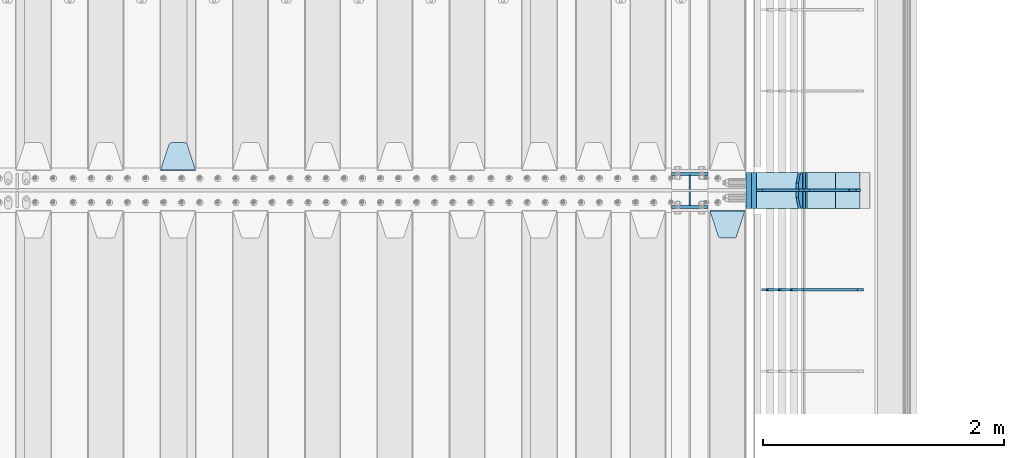
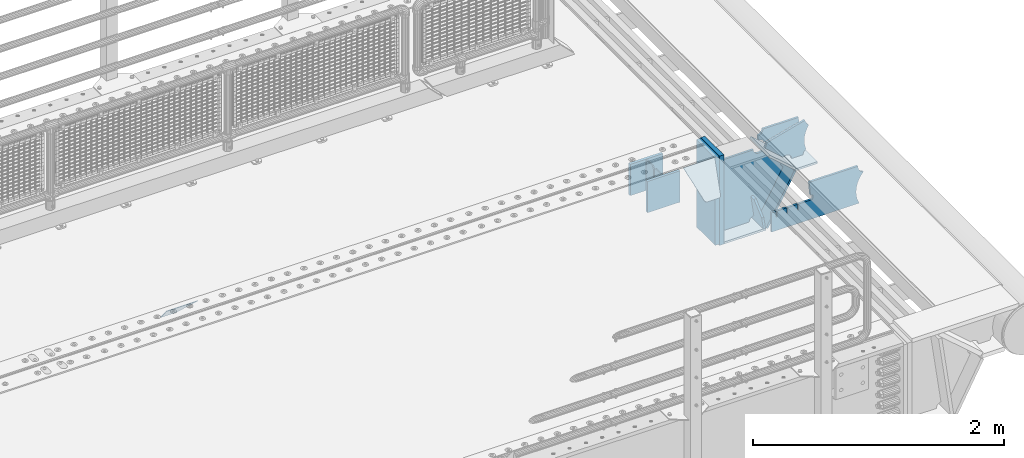
# One storey, part 221 of 242: 17 plates.
"""IFC2X3 building model written with IfcOpenShell, lengths in millimetres."""

from ifc_helpers import new_model, si_unit, frame, origin_with_axes, place, context, subcontext, project, spatial, faceted_brep, material, type_object, element, save


model = new_model("IFC2X3")

# Units and contexts
model_context = context("Model", 3, precision=1e-05, world=origin_with_axes())
body_context = subcontext(model_context, "Body", "Model", "MODEL_VIEW")
ifc_project = project(units=[si_unit("LENGTHUNIT", "METRE", prefix="MILLI"), si_unit("AREAUNIT", "SQUARE_METRE"), si_unit("VOLUMEUNIT", "CUBIC_METRE"), si_unit("MASSUNIT", "GRAM", prefix="KILO"), si_unit("TIMEUNIT", "SECOND"), si_unit("PLANEANGLEUNIT", "RADIAN"), si_unit("SOLIDANGLEUNIT", "STERADIAN"), si_unit("THERMODYNAMICTEMPERATUREUNIT", "DEGREE_CELSIUS"), si_unit("LUMINOUSINTENSITYUNIT", "LUMEN")], contexts=[model_context])

# Site, building, storey
site_placement = place(None, origin_with_axes())
site = spatial("IfcSite", under=ifc_project, at=site_placement, CompositionType="ELEMENT")
building_placement = place(site_placement, origin_with_axes())
building = spatial("IfcBuilding", under=site, at=building_placement, Name="Standard", CompositionType="ELEMENT")
storey_placement = place(building_placement, origin_with_axes())
storey = spatial("IfcBuildingStorey", under=building, at=storey_placement, Name="Undefined", CompositionType="ELEMENT", Elevation=0.0)

# Plates
ifc_material_1 = material(Name="STEEL/S355N")
plate_type_1 = type_object("IfcPlateType", PredefinedType="NOTDEFINED")
for number, where, z_axis, x_axis in (
    (1, (-22682.0, -21137.5, -339.99999999999), (0.0, 0.0, 1.0), (1.0, 0.0, 0.0)),
    (2, (-22682.0, -20862.5, -339.99999999999), (0.0, 0.0, 1.0), (1.0, 0.0, 0.0)),
):
    element("IfcPlate", number, at=place(storey_placement, frame(where, z_axis=z_axis, x_axis=x_axis)), inside=storey, type_object=plate_type_1, material=ifc_material_1, context=body_context, shape_type="Brep", body=[
        faceted_brep([(0.0, -12.5, 0.0), (0.0, -12.5, 305.0), (0.0, 12.5, 305.0), (0.0, 12.5, 0.0), (300.0, -12.5, 305.0), (300.0, 12.5, 305.0), (300.0, -12.5, 0.0), (300.0, 12.5, 0.0)], [[[0, 1, 2, 3]], [[1, 4, 5, 2]], [[4, 6, 7, 5]], [[6, 0, 3, 7]], [[5, 7, 3, 2]], [[6, 4, 1, 0]]]),
    ])
plate_type_2 = type_object("IfcPlateType", PredefinedType="NOTDEFINED")
plate_1_placement = place(storey_placement, frame((-26635.0, -20831.767766953, -1.76776695296758), z_axis=(0.0, 0.707106781186547, -0.707106781186548), x_axis=(-1.0, 0.0, 0.0)))
element("IfcPlate", 3, at=plate_1_placement, inside=storey, type_object=plate_type_2, material=ifc_material_1, context=body_context, shape_type="Brep", body=[
    faceted_brep([(0.0, -2.5, 0.0), (69.345504679477, -2.50000000000182, 300.171731424829), (69.345504679477, 2.5, 300.171731424829), (0.0, 2.5, 0.0), (70.9274061199576, -2.5, 304.897442415398), (70.9274061199576, 2.5, 304.897442415398), (73.3818627772307, -2.5, 309.234538108525), (73.3818627772307, 2.50000000000182, 309.234538108529), (76.6187032999551, -2.5, 313.023683126101), (76.6187032999551, 2.50000000000182, 313.023683126103), (80.5190132704993, -2.5, 316.12567259537), (80.5190132704993, 2.5, 316.12567259537), (84.9395038596849, -2.5, 318.426546230474), (84.9395038596849, 2.50000000000182, 318.426546230476), (89.7177759439219, -2.49999999999818, 319.841774983273), (89.7177759439219, 2.50000000000182, 319.841774983273), (94.678286292652, -2.5, 320.319366455076), (94.678286292652, 2.5, 320.319366455076), (195.321713707348, -2.5, 320.319366455076), (195.321713707348, 2.5, 320.319366455076), (200.282224056078, -2.5, 319.841774983272), (200.282224056078, 2.50000000000182, 319.841774983273), (205.060496140315, -2.5, 318.426546230474), (205.060496140315, 2.49999999999818, 318.426546230474), (209.480986729501, -2.49999999999818, 316.12567259537), (209.480986729501, 2.5, 316.12567259537), (213.381296700045, -2.5, 313.023683126101), (213.381296700045, 2.49999999999818, 313.023683126101), (216.618137222769, -2.5, 309.234538108525), (216.618137222769, 2.5, 309.234538108523), (219.072593880042, -2.49999999999818, 304.897442415398), (219.072593880042, 2.50000000000182, 304.897442415398), (220.654495320523, -2.50000000000182, 300.171731424829), (220.654495320523, 2.5, 300.171731424829), (290.0, -2.5, 0.0), (290.0, 2.5, -1.81898940354586e-12)], [[[0, 1, 2, 3]], [[1, 4, 5, 2]], [[4, 6, 7, 5]], [[6, 8, 9, 7]], [[8, 10, 11, 9]], [[10, 12, 13, 11]], [[12, 14, 15, 13]], [[14, 16, 17, 15]], [[16, 18, 19, 17]], [[18, 20, 21, 19]], [[20, 22, 23, 21]], [[22, 24, 25, 23]], [[24, 26, 27, 25]], [[26, 28, 29, 27]], [[28, 30, 31, 29]], [[30, 32, 33, 31]], [[32, 34, 35, 33]], [[34, 0, 3, 35]], [[5, 7, 9, 11, 13, 15, 17, 19, 21, 23, 25, 27, 29, 31, 33, 35, 3, 2]], [[34, 32, 30, 28, 26, 24, 22, 20, 18, 16, 14, 12, 10, 8, 6, 4, 1, 0]]]),
])
plate_2_placement = place(storey_placement, frame((-22365.0, -21168.232233044, -1.76776695296576), z_axis=(0.0, -0.707106781186547, -0.707106781186548), x_axis=(1.0, 0.0, 0.0)))
element("IfcPlate", 4, at=plate_2_placement, inside=storey, type_object=plate_type_2, material=ifc_material_1, context=body_context, shape_type="Brep", body=[
    faceted_brep([(0.0, -2.5, 0.0), (69.345504679477, -2.50000000000182, 300.171731424829), (69.345504679477, 2.5, 300.171731424829), (0.0, 2.5, 0.0), (70.9274061199576, -2.5, 304.897442415398), (70.9274061199576, 2.5, 304.897442415398), (73.3818627772307, -2.5, 309.234538108525), (73.3818627772307, 2.50000000000182, 309.234538108529), (76.6187032999551, -2.5, 313.023683126101), (76.6187032999551, 2.50000000000182, 313.023683126103), (80.5190132704993, -2.5, 316.12567259537), (80.5190132704993, 2.5, 316.12567259537), (84.9395038596849, -2.5, 318.426546230474), (84.9395038596849, 2.50000000000182, 318.426546230476), (89.7177759439219, -2.49999999999818, 319.841774983273), (89.7177759439219, 2.50000000000182, 319.841774983273), (94.678286292652, -2.5, 320.319366455076), (94.678286292652, 2.5, 320.319366455076), (195.321713707348, -2.5, 320.319366455076), (195.321713707348, 2.5, 320.319366455076), (200.282224056078, -2.5, 319.841774983272), (200.282224056078, 2.50000000000182, 319.841774983273), (205.060496140315, -2.5, 318.426546230474), (205.060496140315, 2.49999999999818, 318.426546230474), (209.480986729501, -2.49999999999818, 316.12567259537), (209.480986729501, 2.5, 316.12567259537), (213.381296700045, -2.5, 313.023683126101), (213.381296700045, 2.49999999999818, 313.023683126101), (216.618137222769, -2.5, 309.234538108525), (216.618137222769, 2.5, 309.234538108523), (219.072593880042, -2.49999999999818, 304.897442415398), (219.072593880042, 2.50000000000182, 304.897442415398), (220.654495320523, -2.50000000000182, 300.171731424829), (220.654495320523, 2.5, 300.171731424829), (290.0, -2.5, 0.0), (290.0, 2.5, -1.81898940354586e-12)], [[[0, 1, 2, 3]], [[1, 4, 5, 2]], [[4, 6, 7, 5]], [[6, 8, 9, 7]], [[8, 10, 11, 9]], [[10, 12, 13, 11]], [[12, 14, 15, 13]], [[14, 16, 17, 15]], [[16, 18, 19, 17]], [[18, 20, 21, 19]], [[20, 22, 23, 21]], [[22, 24, 25, 23]], [[24, 26, 27, 25]], [[26, 28, 29, 27]], [[28, 30, 31, 29]], [[30, 32, 33, 31]], [[32, 34, 35, 33]], [[34, 0, 3, 35]], [[5, 7, 9, 11, 13, 15, 17, 19, 21, 23, 25, 27, 29, 31, 33, 35, 3, 2]], [[34, 32, 30, 28, 26, 24, 22, 20, 18, 16, 14, 12, 10, 8, 6, 4, 1, 0]]]),
])
ifc_material_2 = material()
plate_type_3 = type_object("IfcPlateType", PredefinedType="NOTDEFINED")
plate_3_placement = place(storey_placement, frame((-22000.0011701094, -20850.0, -889.999999999995), z_axis=(0.0, 0.0, 1.0), x_axis=(0.0, -1.0, 0.0)))
element("IfcPlate", 5, at=plate_3_placement, inside=storey, type_object=plate_type_3, material=ifc_material_2, context=body_context, shape_type="Brep", body=[
    faceted_brep([(0.0, -20.0, 0.0), (0.0, -20.0, 870.0), (0.0, 20.0, 870.0), (0.0, 20.0, 0.0), (300.0, -20.0, 870.0), (300.0, 20.0, 870.0), (300.0, -20.0, 3.63797880709171e-12), (300.0, 20.0, 3.63797880709171e-12)], [[[0, 1, 2, 3]], [[1, 4, 5, 2]], [[4, 6, 7, 5]], [[6, 0, 3, 7]], [[5, 7, 3, 2]], [[6, 4, 1, 0]]]),
])
plate_4_placement = place(storey_placement, frame((-22040.0, -20850.0, -875.0), z_axis=(0.0, 0.0, 1.0), x_axis=(0.0, -1.0, 0.0)))
element("IfcPlate", 6, at=plate_4_placement, inside=storey, type_object=plate_type_3, material=ifc_material_2, context=body_context, shape_type="Brep", body=[
    faceted_brep([(0.0, -20.0, 0.0), (9.5367431640625e-07, -20.0, 850.0), (9.5367431640625e-07, 20.0, 850.0), (0.0, 20.0, 0.0), (300.0, -20.0, 850.0), (300.0, 20.0, 850.0), (300.0, -20.0, 3.63797880709171e-12), (300.0, 20.0, 3.63797880709171e-12)], [[[0, 1, 2, 3]], [[1, 4, 5, 2]], [[4, 6, 7, 5]], [[6, 0, 3, 7]], [[5, 7, 3, 2]], [[6, 4, 1, 0]]]),
])
plate_type_4 = type_object("IfcPlateType", PredefinedType="NOTDEFINED")
plate_5_placement = place(storey_placement, frame((-21094.0817660324, -21825.0007171631, -374.002067436516), z_axis=(0.0, 0.0, 1.0), x_axis=(-1.0, 0.0, 0.0)))
element("IfcPlate", 7, at=plate_5_placement, inside=storey, type_object=plate_type_4, material=ifc_material_1, context=body_context, shape_type="Brep", body=[
    faceted_brep([(801.919404066546, -10.0, 188.0), (801.919404066546, 10.0, 188.0), (801.919404066546, 10.0, 132.002067436952), (801.919404066546, -10.0, 132.002067436952), (793.919404066546, 10.0, 132.002067436952), (793.919404066546, -10.0, 132.002067436952), (793.919404066546, 10.0, 180.002067436952), (793.919404066546, -10.0, 180.002067436952), (793.527856196906, 10.0, 182.474203391951), (793.527856196906, -10.0, 182.474203391951), (792.391540021545, 10.0, 184.704349455291), (792.391540021545, -10.0, 184.704349455291), (790.621686084887, 10.0, 186.474203391951), (790.621686084887, -10.0, 186.474203391951), (788.391540021545, 10.0, 187.610519567313), (788.391540021545, -10.0, 187.610519567313), (785.919404066546, -10.0, 188.002067436952), (785.919404066546, 10.0, 188.0), (841.0, -10.0, 188.0), (841.0, -10.0, 0.0), (841.0, 10.0, 0.0), (841.0, 10.0, 188.0), (33.3619566735979, -10.0, 0.0), (33.3619566735979, 10.0, 0.0), (36.2350612208174, -10.0, 4.68848050267007), (36.2350612208174, 10.0, 4.68848050267007), (51.4877592159428, -10.0, 41.5117508652783), (51.4877592159428, 10.0, 41.5117508652783), (60.792242588137, -10.0, 80.2677133162963), (60.792242588137, 10.0, 80.2677133162963), (63.9194040769726, -10.0, 120.002067436515), (63.9194040769726, 10.0, 120.002067436515), (60.792242588137, -10.0, 159.736421556734), (60.792242588137, 10.0, 159.736421556734), (51.4877592159428, -10.0, 198.492384007752), (51.4877592159428, 10.0, 198.492384007752), (36.2350612208174, -10.0, 235.31565437036), (36.2350612208174, 10.0, 235.31565437036), (15.4097206482074, -10.0, 269.299521518803), (15.4097206482074, 10.0, 269.299521518803), (-3.35474438098754, -10.0, 291.269887256574), (-3.35474438098754, 10.0, 291.269887256574), (-2.36881039375294, -10.0, 291.426043859339), (-2.36881039375294, 10.0, 291.426043859339), (17.1449676604716, -10.0, 301.368810393754), (17.1449676604716, 10.0, 301.368810393754), (32.6311896062471, -10.0, 316.855032339527), (32.6311896062471, 10.0, 316.855032339527), (42.573956140659, -10.0, 336.368810393754), (42.573956140659, 10.0, 336.368810393754), (46.0, -10.0, 358.0), (46.0, 10.0, 358.0), (45.0495205499137, -10.0, 364.001091067617), (45.0495205499137, 10.0, 364.001091067617), (495.040008544922, -10.0, 364.010009765625), (495.040008544922, 10.0, 364.010009765625), (483.600036621094, -10.0, 233.759994506836), (483.600036621094, 10.0, 233.759994506836), (472.0, -10.0, 233.759994506836), (472.0, 10.0, 233.759994506836), (468.909830056251, -10.0, 233.270559669787), (468.909830056251, 10.0, 233.270559669787), (466.122147477075, -10.0, 231.850164450585), (466.122147477075, 10.0, 231.850164450585), (463.909830056251, -10.0, 229.637847029761), (463.909830056251, 10.0, 229.637847029761), (462.489434837047, -10.0, 226.850164450585), (462.489434837047, 10.0, 226.850164450585), (462.0, -10.0, 223.759994506836), (462.0, 10.0, 223.759994506836), (462.0, -10.0, 198.0), (462.0, 10.0, 198.0), (462.489434837047, -10.0, 194.909830056251), (462.489434837047, 10.0, 194.909830056251), (463.909830056251, -10.0, 192.122147477075), (463.909830056251, 10.0, 192.122147477075), (466.122147477075, -10.0, 189.909830056251), (466.122147477075, 10.0, 189.909830056251), (468.909830056251, -10.0, 188.489434837048), (468.909830056251, 10.0, 188.489434837048), (472.0, -10.0, 188.0), (472.0, 10.0, 188.0), (585.919404066546, -10.0, 188.002067436952), (585.919404066546, 10.0, 188.0), (588.391540021545, -10.0, 187.610519567313), (588.391540021545, 10.0, 187.610519567313), (590.621686084887, -10.0, 186.474203391951), (590.621686084887, 10.0, 186.474203391951), (592.391540021545, -10.0, 184.704349455291), (592.391540021545, 10.0, 184.704349455291), (593.527856196906, -10.0, 182.474203391951), (593.527856196906, 10.0, 182.474203391951), (593.919404066546, -10.0, 180.002067436952), (593.919404066546, 10.0, 180.002067436952), (593.919404066546, -10.0000000000036, 132.002067436952), (593.919404066546, 10.0, 132.002067436952), (601.919404066546, -10.0000000000036, 132.002067436952), (601.919404066546, 10.0, 132.002067436952), (601.919404066546, -10.0, 188.0), (601.919404066546, 10.0, 188.0), (685.919404066546, -10.0, 188.002067436952), (685.919404066546, 10.0, 188.0), (688.391540021545, -10.0, 187.610519567313), (688.391540021545, 10.0, 187.610519567313), (690.621686084887, -10.0, 186.474203391951), (690.621686084887, 10.0, 186.474203391951), (692.391540021545, -10.0, 184.704349455291), (692.391540021545, 10.0, 184.704349455291), (693.527856196906, -10.0, 182.474203391951), (693.527856196906, 10.0, 182.474203391951), (693.919404066546, -10.0, 180.002067436952), (693.919404066546, 10.0, 180.002067436952), (693.919404066546, -10.0, 132.002067436952), (693.919404066546, 10.0, 132.002067436952), (701.919404066546, -10.0, 132.002067436952), (701.919404066546, 10.0, 132.002067436952), (701.919404066546, -10.0, 188.0), (701.919404066546, 10.0, 188.0)], [[[0, 1, 2, 3]], [[3, 2, 4, 5]], [[5, 4, 6, 7]], [[7, 6, 8, 9]], [[9, 8, 10, 11]], [[11, 10, 12, 13]], [[13, 12, 14, 15]], [[16, 15, 14, 17]], [[18, 19, 20, 21]], [[20, 19, 22, 23]], [[22, 24, 25, 23]], [[26, 27, 25, 24]], [[28, 29, 27, 26]], [[30, 31, 29, 28]], [[32, 33, 31, 30]], [[34, 35, 33, 32]], [[36, 37, 35, 34]], [[38, 39, 37, 36]], [[39, 38, 40, 41]], [[40, 42, 43, 41]], [[44, 45, 43, 42]], [[46, 47, 45, 44]], [[48, 49, 47, 46]], [[50, 51, 49, 48]], [[52, 53, 51, 50]], [[54, 55, 53, 52]], [[54, 56, 57, 55]], [[56, 58, 59, 57]], [[58, 60, 61, 59]], [[60, 62, 63, 61]], [[62, 64, 65, 63]], [[64, 66, 67, 65]], [[66, 68, 69, 67]], [[68, 70, 71, 69]], [[70, 72, 73, 71]], [[72, 74, 75, 73]], [[74, 76, 77, 75]], [[76, 78, 79, 77]], [[78, 80, 81, 79]], [[81, 80, 82, 83]], [[82, 84, 85, 83]], [[86, 87, 85, 84]], [[88, 89, 87, 86]], [[90, 91, 89, 88]], [[92, 93, 91, 90]], [[94, 95, 93, 92]], [[96, 97, 95, 94]], [[98, 99, 97, 96]], [[99, 98, 100, 101]], [[100, 102, 103, 101]], [[104, 105, 103, 102]], [[106, 107, 105, 104]], [[108, 109, 107, 106]], [[110, 111, 109, 108]], [[112, 113, 111, 110]], [[114, 115, 113, 112]], [[116, 117, 115, 114]], [[117, 116, 16, 17]], [[12, 10, 8, 6, 4, 2, 1, 21, 20, 23, 25, 27, 29, 31, 33, 35, 37, 39, 41, 43, 45, 47, 49, 51, 53, 55, 57, 59, 61, 63, 65, 67, 69, 71, 73, 75, 77, 79, 81, 83, 85, 87, 89, 91, 93, 95, 97, 99, 101, 103, 105, 107, 109, 111, 113, 115, 117, 17, 14]], [[18, 21, 1, 0]], [[116, 114, 112, 110, 108, 106, 104, 102, 100, 98, 96, 94, 92, 90, 88, 86, 84, 82, 80, 78, 76, 74, 72, 70, 68, 66, 64, 62, 60, 58, 56, 54, 52, 50, 48, 46, 44, 42, 40, 38, 36, 34, 32, 30, 28, 26, 24, 22, 19, 18, 0, 3, 5, 7, 9, 11, 13, 15, 16]]]),
])
plate_type_5 = type_object("IfcPlateType", PredefinedType="NOTDEFINED")
plate_6_placement = place(storey_placement, frame((-21605.9224668054, -20849.9999999983, -871.412303810021), z_axis=(0.0, -1.0, 0.0), x_axis=(-0.137902988002447, 0.0, 0.990445741017648)))
element("IfcPlate", 8, at=plate_6_placement, inside=storey, type_object=plate_type_5, material=ifc_material_1, context=body_context, shape_type="Brep", body=[
    faceted_brep([(0.0, -10.0, 0.0), (-1.97815097635612e-10, -9.99999999999636, 300.0), (-1.97815097635612e-10, 10.0000000000073, 300.0), (0.0, 10.0, 0.0), (115.0, -9.99999999999272, 300.0), (115.0, 10.0000000000036, 300.0), (250.000000000001, -9.99999999999272, 210.0), (250.000000000001, 10.0000000000036, 210.0), (250.000000000001, -9.99999999999272, 90.0), (250.000000000001, 10.0000000000036, 90.0), (115.0, -9.99999999999272, -1.09139364212751e-10), (115.0, 10.0000000000036, -1.09139364212751e-10)], [[[0, 1, 2, 3]], [[1, 4, 5, 2]], [[4, 6, 7, 5]], [[6, 8, 9, 7]], [[8, 10, 11, 9]], [[10, 0, 3, 11]], [[5, 7, 9, 11, 3, 2]], [[10, 8, 6, 4, 1, 0]]]),
])
plate_type_6 = type_object("IfcPlateType", PredefinedType="NOTDEFINED")
plate_7_placement = place(storey_placement, frame((-21577.0011701087, -20999.9999999999, -179.999999999866), z_axis=(0.0, 0.0, -1.0), x_axis=(-1.0, 0.0, 0.0)))
element("IfcPlate", 9, at=plate_7_placement, inside=storey, type_object=plate_type_6, material=ifc_material_1, context=body_context, shape_type="Brep", body=[
    faceted_brep([(46.0258547361482, 10.0, 641.078828352486), (73.3015011074858, 10.0000000000073, 445.179898435786), (73.3015011074858, -9.99999999998909, 445.179898435786), (46.0258547361482, -10.0, 641.078828352486), (53.4925862871314, 10.0000000000073, 442.421838675737), (53.4925862871314, -9.99999999998909, 442.421838675737), (25.782050112397, 10.0, 641.444230671289), (25.782050112397, -10.0, 641.444230671289), (54.6652503111618, 10.0, 642.447174185377), (54.6652503111618, -10.0, 642.447174185377), (68.6036632070354, -10.0, 649.549150281387), (68.6036632070354, 10.0, 649.549150281387), (79.6652503111618, -10.0, 660.610737385511), (79.6652503111618, 10.0, 660.610737385511), (86.7672264071698, -10.0, 674.549150281387), (86.7672264071698, 10.0, 674.549150281387), (89.2144005924129, -10.0, 690.0), (89.2144005924129, 10.0, 690.0), (353.0, -10.0, 690.0), (353.0, 10.0, 690.0), (355.447174185243, -10.0, 674.549150281253), (355.447174185243, 10.0, 674.549150281253), (362.549150281251, -10.0, 660.610737385376), (362.549150281251, 10.0, 660.610737385376), (373.610737385377, -10.0, 649.549150281253), (373.610737385377, 10.0, 649.549150281253), (387.549150281251, -10.0, 642.447174185242), (387.549150281251, 10.0, 642.447174185242), (403.0, -10.0, 640.0), (403.0, 10.0, 640.0), (403.0, -10.0, 50.0), (403.0, 10.0, 50.0), (387.549150281251, -10.0, 47.5528258147577), (387.549150281251, 10.0, 47.5528258147577), (373.610737385377, -10.0, 40.4508497187474), (373.610737385377, 10.0, 40.4508497187474), (362.549150281251, -10.0, 29.3892626146236), (362.549150281251, 10.0, 29.3892626146236), (355.447174185243, -10.0, 15.4508497187474), (355.447174185243, 10.0, 15.4508497187474), (353.0, -10.0, 0.0), (353.0, 10.0, 0.0), (50.0, -10.0, 0.0), (50.0, 10.0, 0.0), (47.0349915316328, -10.0, 16.9620037619133), (47.0349915316328, 10.0, 16.9620037619133), (38.4916171352343, -10.0, 31.9123081320451), (38.4916171352343, 10.0, 31.9123081320451), (25.3831239081519, -10.0, 43.0778019479116), (25.3831239081519, 10.0, 43.0778019479116), (9.26418358741648, -10.0, 49.1342538608113), (9.26418358741648, 10.0, 49.1342538608113), (-7.95349204488593, -10.0, 49.363366622344), (-7.95349204488593, 10.0, 49.363366622344), (-24.2278808265401, -10.0, 43.7379673813837), (-24.2278808265401, 10.0, 43.7379673813837), (-37.6288347353438, -10.0, 32.9252303934259), (-37.6288347353438, 10.0, 32.9252303934259), (-210.371165264656, -10.0, 184.074769606574), (-210.371165264656, 10.0, 184.074769606574), (-202.382363280569, -10.0, 196.529747922069), (-202.382363280569, 10.0, 196.529747922069), (-198.388707244045, -10.0, 210.777489969227), (-198.388707244045, 10.0, 210.777489969227), (-198.739957464426, -10.0, 225.570193077959), (-198.739957464426, 10.0, 225.570193077959), (-203.40535180681, -10.0, 239.612327446012), (-203.40535180681, 10.0, 239.612327446012), (-211.976299808361, -10.0, 251.674097313455), (-211.976299808361, 10.0, 251.674097313455), (-223.702166612962, -10.0, 260.699145216992), (-223.702166612962, 10.0, 260.699145216992), (-9.29783338703783, -10.0, 646.300854783008), (-9.29783338703783, 10.0, 646.300854783008), (6.98069453597782, -10.0, 640.647282345602), (6.98069453597782, 10.0, 640.647282345602), (24.2117663163663, -10.0, 640.855891896051), (24.2117663163663, 10.0, 640.855891896051)], [[[0, 1, 2, 3]], [[4, 5, 2, 1]], [[6, 7, 5, 4]], [[8, 9, 10, 11]], [[11, 10, 12, 13]], [[13, 12, 14, 15]], [[15, 14, 16, 17]], [[18, 19, 17, 16]], [[18, 20, 21, 19]], [[20, 22, 23, 21]], [[22, 24, 25, 23]], [[24, 26, 27, 25]], [[26, 28, 29, 27]], [[28, 30, 31, 29]], [[30, 32, 33, 31]], [[32, 34, 35, 33]], [[34, 36, 37, 35]], [[36, 38, 39, 37]], [[38, 40, 41, 39]], [[40, 42, 43, 41]], [[42, 44, 45, 43]], [[44, 46, 47, 45]], [[46, 48, 49, 47]], [[48, 50, 51, 49]], [[50, 52, 53, 51]], [[52, 54, 55, 53]], [[54, 56, 57, 55]], [[56, 58, 59, 57]], [[58, 60, 61, 59]], [[60, 62, 63, 61]], [[62, 64, 65, 63]], [[64, 66, 67, 65]], [[66, 68, 69, 67]], [[68, 70, 71, 69]], [[70, 72, 73, 71]], [[72, 74, 75, 73]], [[74, 76, 77, 75]], [[1, 0, 8, 11, 13, 15, 17, 19, 21, 23, 25, 27, 29, 31, 33, 35, 37, 39, 41, 43, 45, 47, 49, 51, 53, 55, 57, 59, 61, 63, 65, 67, 69, 71, 73, 75, 77, 6, 4]], [[9, 8, 0, 3]], [[76, 74, 72, 70, 68, 66, 64, 62, 60, 58, 56, 54, 52, 50, 48, 46, 44, 42, 40, 38, 36, 34, 32, 30, 28, 26, 24, 22, 20, 18, 16, 14, 12, 10, 9, 3, 2, 5, 7]], [[77, 76, 7, 6]]]),
])
plate_type_7 = type_object("IfcPlateType", PredefinedType="NOTDEFINED")
plate_8_placement = place(storey_placement, frame((-21036.0011497488, -21000.0000000007, -28.9999913318487), z_axis=(0.260769276985653, 0.0, -0.965401151946889), x_axis=(-0.965401151946889, 0.0, -0.260769276985654)))
element("IfcPlate", 10, at=plate_8_placement, inside=storey, type_object=plate_type_7, material=ifc_material_1, context=body_context, shape_type="Brep", body=[
    faceted_brep([(183.436474692327, 10.0, 275.852500330424), (184.918388609061, 10.0, 264.417843531322), (184.918388609061, -10.0, 264.417843531322), (183.436474692327, -10.0, 275.852500330424), (183.794583267616, 10.0, 224.576469334608), (183.794583267616, -10.0, 224.576469334608), (176.452049775839, 10.0, 185.401410454622), (176.452049775839, -10.0, 185.401410454622), (163.071585676771, 10.0, 147.857286855558), (163.071585676771, -10.0, 147.857286855558), (143.982662403749, 10.0, 112.868559462227), (143.982662403749, -10.0, 112.868559462227), (119.655312600255, 10.0, 81.2967668639831), (119.655312600255, -10.0, 81.2967668639831), (100.960891712752, 10.0, 63.6280409830933), (100.960891712752, -10.0, 63.6280409830933), (194.486836975906, -10.0, 278.751956446687), (207.178624553377, -10.0, 286.650994937515), (207.178624553377, 10.0, 286.650994937515), (194.486836975906, 10.0, 278.751956446687), (216.96801346945, -10.0, 297.948965801394), (216.96801346945, 10.0, 297.948965801394), (222.979925232867, -10.0, 311.635937633766), (222.979925232867, 10.0, 311.635937633766), (323.381647032766, -10.0, 284.515917834983), (323.381647032766, 10.0, 284.515917834983), (321.72061717734, -10.0, 268.853198956859), (321.72061717734, 10.0, 268.853198956859), (325.01434448114, -10.0, 253.450889283181), (325.01434448114, 10.0, 253.450889283181), (332.935986082484, -10.0, 239.837389469553), (332.935986082484, 10.0, 239.837389469553), (344.699462330093, -10.0, 229.363593146935), (344.699462330093, 10.0, 229.363593146935), (359.137460970807, -10.0, 223.0688351622), (359.137460970807, 10.0, 223.0688351622), (374.817271777687, -10.0, 221.57775639289), (374.817271777687, 10.0, 221.57775639289), (390.182952880859, -10.0, 225.038330078124), (390.182952880859, 10.0, 225.038330078124), (512.90906051303, -10.0, 41.5599003357011), (512.90906051303, 10.0, 41.5599003357011), (503.648024844584, -10.0, 33.5643666747674), (503.648024844584, 10.0, 33.5643666747674), (496.606064569703, -10.0, 23.5590612989981), (496.606064569703, 10.0, 23.5590612989981), (492.204839143935, -10.0, 12.1430832451069), (492.204839143935, 10.0, 12.1430832451069), (490.707885742188, -10.0, 3.80168785341084e-10), (490.707885742188, 10.0, 3.80168785341084e-10), (120.0, -10.0, 9.27684595808387e-11), (120.0, 10.0, 9.27684595808387e-11), (117.226254779114, -10.0, 25.6516118492145), (117.226254779114, 10.0, 25.6516118492145), (109.03324682566, -10.0, 50.1173731020981), (109.03324682566, 10.0, 50.1173731020981)], [[[0, 1, 2, 3]], [[4, 5, 2, 1]], [[6, 7, 5, 4]], [[8, 9, 7, 6]], [[10, 11, 9, 8]], [[12, 13, 11, 10]], [[14, 15, 13, 12]], [[16, 17, 18, 19]], [[17, 20, 21, 18]], [[20, 22, 23, 21]], [[22, 24, 25, 23]], [[24, 26, 27, 25]], [[26, 28, 29, 27]], [[28, 30, 31, 29]], [[30, 32, 33, 31]], [[32, 34, 35, 33]], [[34, 36, 37, 35]], [[36, 38, 39, 37]], [[38, 40, 41, 39]], [[40, 42, 43, 41]], [[42, 44, 45, 43]], [[44, 46, 47, 45]], [[46, 48, 49, 47]], [[48, 50, 51, 49]], [[50, 52, 53, 51]], [[52, 54, 55, 53]], [[10, 8, 6, 4, 1, 0, 19, 18, 21, 23, 25, 27, 29, 31, 33, 35, 37, 39, 41, 43, 45, 47, 49, 51, 53, 55, 14, 12]], [[16, 19, 0, 3]], [[54, 52, 50, 48, 46, 44, 42, 40, 38, 36, 34, 32, 30, 28, 26, 24, 22, 20, 17, 16, 3, 2, 5, 7, 9, 11, 13, 15]], [[55, 54, 15, 14]]]),
])
plate_type_8 = type_object("IfcPlateType", PredefinedType="NOTDEFINED")
plate_9_placement = place(storey_placement, frame((-21564.7739409557, -20850.0000000007, -177.219372761326), z_axis=(0.752414935148685, 0.0, -0.658689430130164), x_axis=(0.0, -1.0, 0.0)))
element("IfcPlate", 11, at=plate_9_placement, inside=storey, type_object=plate_type_8, material=ifc_material_1, context=body_context, shape_type="Brep", body=[
    faceted_brep([(0.0, -10.0, 0.0), (1.09139364212751e-10, -9.99999999999818, 320.000000000004), (1.09139364212751e-10, 10.0000000000036, 320.000000000002), (0.0, 10.0, 0.0), (300.0, -9.99999999999818, 320.000000000004), (300.0, 10.0000000000036, 320.000000000002), (300.0, -9.99999999999636, 6.91215973347425e-11), (300.0, 10.0000000000018, 6.91215973347425e-11)], [[[0, 1, 2, 3]], [[1, 4, 5, 2]], [[4, 6, 7, 5]], [[6, 0, 3, 7]], [[5, 7, 3, 2]], [[6, 4, 1, 0]]]),
])
plate_10_placement = place(storey_placement, frame((-21323.9992711892, -20849.9999999999, -408.004820491625), z_axis=(-0.484064236150485, 0.0, -0.875032465272031), x_axis=(0.0, -1.0, 0.0)))
element("IfcPlate", 12, at=plate_10_placement, inside=storey, type_object=plate_type_8, material=ifc_material_1, context=body_context, shape_type="Brep", body=[
    faceted_brep([(0.0, -10.0, 0.0), (3.86513420380652e-07, -9.99999999999636, 533.528442382814), (3.86513420380652e-07, 10.0, 533.528442382814), (0.0, 10.0, 0.0), (300.003295898438, -9.99999999999636, 533.549133300783), (300.003295898438, 10.0, 533.549133300783), (300.0, -9.99999999999636, 6.91215973347425e-11), (300.0, 10.0000000000018, 6.91215973347425e-11)], [[[0, 1, 2, 3]], [[1, 4, 5, 2]], [[4, 6, 7, 5]], [[6, 0, 3, 7]], [[5, 7, 3, 2]], [[6, 4, 1, 0]]]),
])
plate_11_placement = place(storey_placement, frame((-21980.0011701087, -20849.9999999999, -879.999999999866), z_axis=(0.0, -1.0, 0.0), x_axis=(1.0, 0.0, 0.0)))
element("IfcPlate", 13, at=plate_11_placement, inside=storey, type_object=plate_type_8, material=ifc_material_1, context=body_context, shape_type="Brep", body=[
    faceted_brep([(0.0, -10.0, 0.0), (-1.97815097635612e-10, -9.99999999999636, 300.0), (-1.97815097635612e-10, 10.0000000000073, 300.0), (0.0, 10.0, 0.0), (389.0, -10.0, 300.0), (389.0, 10.0, 300.0), (389.0, -10.0, 0.0), (389.0, 10.0, 0.0)], [[[0, 1, 2, 3]], [[1, 4, 5, 2]], [[4, 6, 7, 5]], [[6, 0, 3, 7]], [[5, 7, 3, 2]], [[6, 4, 1, 0]]]),
])
plate_type_9 = type_object("IfcPlateType", PredefinedType="NOTDEFINED")
plate_12_placement = place(storey_placement, frame((-21120.0011701087, -20850.0000000007, -397.999999999763), z_axis=(-1.0, 0.0, 0.0), x_axis=(0.0, -1.0, 0.0)))
element("IfcPlate", 14, at=plate_12_placement, inside=storey, type_object=plate_type_9, material=ifc_material_1, context=body_context, shape_type="Brep", body=[
    faceted_brep([(0.0, -10.0, 0.0), (4.65661287307739e-10, -10.0, 204.0), (4.65661287307739e-10, 10.0, 204.0), (0.0, 10.0, 0.0), (300.0, -10.0, 204.0), (300.0, 10.0, 204.0), (300.0, -9.99999999999636, 6.91215973347425e-11), (300.0, 10.0000000000018, 6.91215973347425e-11)], [[[0, 1, 2, 3]], [[1, 4, 5, 2]], [[4, 6, 7, 5]], [[6, 0, 3, 7]], [[5, 7, 3, 2]], [[6, 4, 1, 0]]]),
])
plate_type_10 = type_object("IfcPlateType", PredefinedType="NOTDEFINED")
plate_13_placement = place(storey_placement, frame((-21041.0011701094, -21000.0, -9.99999999999716), z_axis=(0.0, 0.0, -1.0), x_axis=(-1.0, 0.0, 0.0)))
element("IfcPlate", 15, at=plate_13_placement, inside=storey, type_object=plate_type_10, material=ifc_material_1, context=body_context, shape_type="Brep", body=[
    faceted_brep([(164.157641141064, -10.0, 44.1844865875018), (486.718340840864, -10.0, 131.004562768382), (486.718340840864, 10.0, 131.004562768382), (164.157641141064, 10.0, 44.1844865875018), (492.179177700767, -10.0, 118.185717565315), (492.179177700767, 10.0, 118.185717565315), (500.965368826703, -10.0, 107.371542744776), (500.965368826703, 10.0, 107.371542744776), (512.394601349042, -10.0, 99.4018391429503), (512.394601349042, 10.0, 99.4018391429503), (525.579310641864, -10.0, 94.8955133209048), (525.579310641864, 10.0, 94.8955133209048), (539.495606295339, -10.0, 94.2025148824028), (539.495606295339, 10.0, 94.2025148824028), (543.504393704661, -10.0, 49.7974851175972), (543.504393704661, 10.0, 49.7974851175972), (529.167086307516, -10.0, 46.3176139481669), (529.167086307516, 10.0, 46.3176139481669), (516.469507120331, -10.0, 38.8049999196639), (516.469507120331, 10.0, 38.8049999196639), (506.517198234546, -10.0, 27.9137449599276), (506.517198234546, 10.0, 27.9137449599276), (500.17667886756, -10.0, 14.592119649441), (500.17667886756, 10.0, 14.592119649441), (498.0, -10.0, 0.0), (498.0, 10.0, 0.0), (170.0, -10.0, 0.0), (170.0, 10.0, 0.0), (169.632873911985, -10.0, 11.1663820622718), (169.632873911985, 10.0, 11.1663820622718), (168.533081313406, -10.0, 22.2845350637931), (168.533081313406, 10.0, 22.2845350637931), (166.705372351957, -10.0, 33.3064382514178), (166.705372351957, 10.0, 33.3064382514178)], [[[0, 1, 2, 3]], [[1, 4, 5, 2]], [[4, 6, 7, 5]], [[6, 8, 9, 7]], [[8, 10, 11, 9]], [[10, 12, 13, 11]], [[12, 14, 15, 13]], [[14, 16, 17, 15]], [[16, 18, 19, 17]], [[18, 20, 21, 19]], [[20, 22, 23, 21]], [[22, 24, 25, 23]], [[24, 26, 27, 25]], [[26, 28, 29, 27]], [[28, 30, 31, 29]], [[30, 32, 33, 31]], [[32, 0, 3, 33]], [[5, 7, 9, 11, 13, 15, 17, 19, 21, 23, 25, 27, 29, 31, 33, 3, 2]], [[32, 30, 28, 26, 24, 22, 20, 18, 16, 14, 12, 10, 8, 6, 4, 1, 0]]]),
])
plate_type_11 = type_object("IfcPlateType", PredefinedType="NOTDEFINED")
for number, where, z_axis, x_axis in (
    (16, (-22532.0, -20990.75, -34.9999999999899), (0.0, 0.0, -1.0), (0.0, 1.0, 0.0)),
    (17, (-22532.0, -21009.25, -34.9999999999899), (0.0, 0.0, -1.0), (0.0, -1.0, 0.0)),
):
    element("IfcPlate", number, at=place(storey_placement, frame(where, z_axis=z_axis, x_axis=x_axis)), inside=storey, type_object=plate_type_11, material=ifc_material_1, context=body_context, shape_type="Brep", body=[
        faceted_brep([(0.0, -5.0, 30.0), (0.0, -5.0, 301.0), (0.0, 5.0, 301.0), (0.0, 5.0, 30.0), (115.75, -5.0, 301.0), (115.75, 5.0, 301.0), (115.75, -5.0, 0.0), (115.75, 5.0, 0.0), (30.0, -5.0, 0.0), (30.0, 5.0, 0.0), (24.7905546699913, -5.0, 0.455767409633758), (24.7905546699913, 5.0, 0.455767409633758), (19.7393957002314, -5.0, 1.80922137642275), (19.7393957002314, 5.0, 1.80922137642275), (15.0, -5.0, 4.01923788646684), (15.0, 5.0, 4.01923788646684), (10.7163717094045, -5.0, 7.01866670643066), (10.7163717094045, 5.0, 7.01866670643066), (7.01866670642994, -5.0, 10.7163717094038), (7.01866670642994, 5.0, 10.7163717094038), (4.01923788646673, -5.0, 15.0), (4.01923788646673, 5.0, 15.0), (1.80922137642119, -5.0, 19.7393957002299), (1.80922137642119, 5.0, 19.7393957002299), (0.455767409632244, -5.0, 24.7905546699921), (0.455767409632244, 5.0, 24.7905546699921)], [[[0, 1, 2, 3]], [[1, 4, 5, 2]], [[4, 6, 7, 5]], [[6, 8, 9, 7]], [[8, 10, 11, 9]], [[10, 12, 13, 11]], [[12, 14, 15, 13]], [[14, 16, 17, 15]], [[16, 18, 19, 17]], [[18, 20, 21, 19]], [[20, 22, 23, 21]], [[22, 24, 25, 23]], [[24, 0, 3, 25]], [[5, 7, 9, 11, 13, 15, 17, 19, 21, 23, 25, 3, 2]], [[24, 22, 20, 18, 16, 14, 12, 10, 8, 6, 4, 1, 0]]]),
    ])

save(model, "model.ifc")
